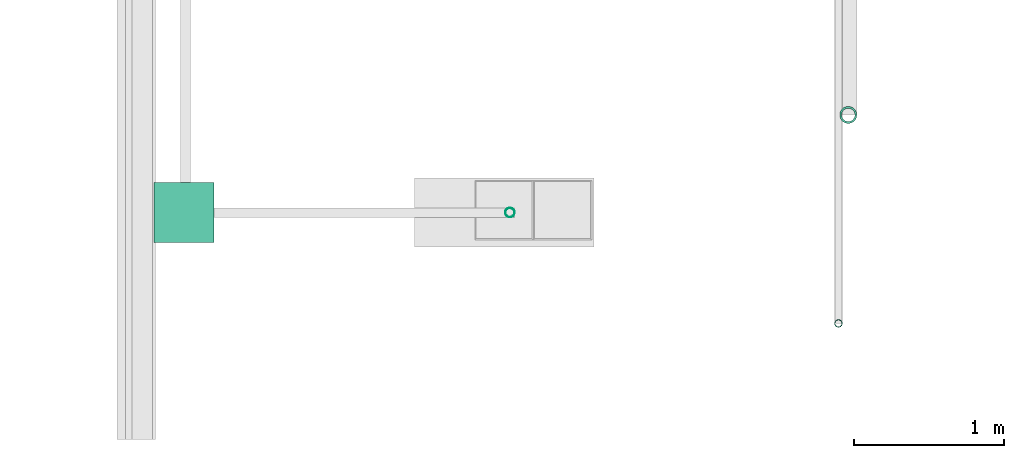
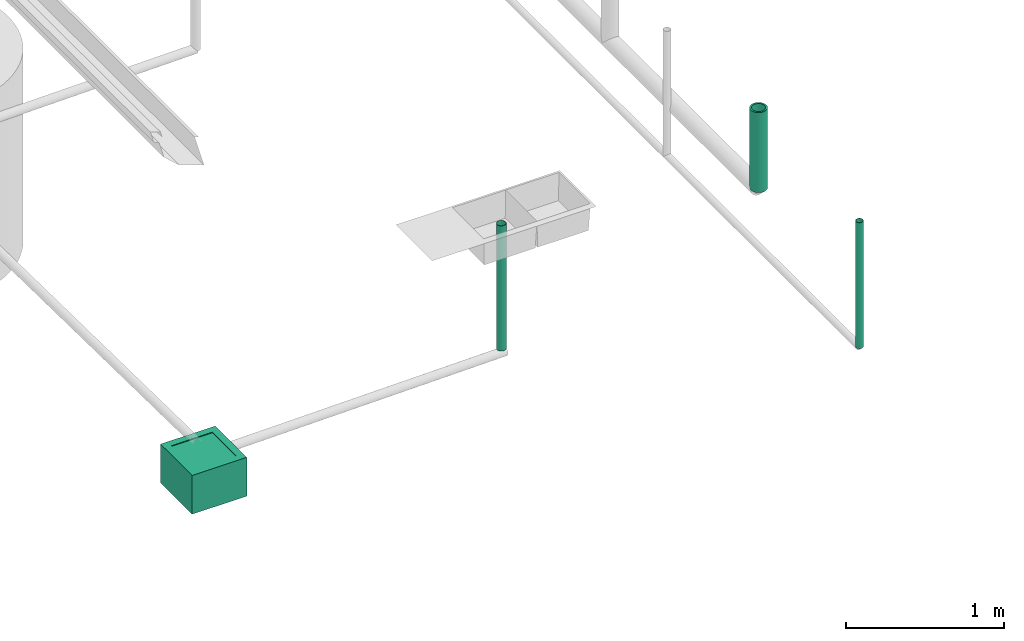
# One storey, part 10 of 15: 3 pipe segments, 2 distribution chamber elements.
"""IFC4X3_ADD2 building model written with IfcOpenShell, lengths in metres."""

from ifc_helpers import new_model, entity, si_unit, converted_unit, frame, origin_with_axes, origin_2d_with_axis, place, context, subcontext, project, spatial, hollow_circle, extrude, clip, halfspace, polygons, source, transform, mapped, material, material_profile, profile_set, profile_usage, type_object, type_shapes, element, save


model = new_model("IFC4X3_ADD2")

# Units and contexts
model_context = context("Model", 3, precision=1e-05, world=origin_with_axes())
plan_context = context("Plan", 2, precision=1e-05, world=origin_2d_with_axis())
body_context = subcontext(model_context, "Body", "Model", "MODEL_VIEW")
ifc_project = project(units=[si_unit("VOLUMEUNIT", "CUBIC_METRE"), si_unit("LENGTHUNIT", "METRE"), converted_unit("PLANEANGLEUNIT", "degree", entity("IfcReal", 0.0174532925199433), si_unit("PLANEANGLEUNIT", "RADIAN"), dimensions=[0, 0, 0, 0, 0, 0, 0]), si_unit("AREAUNIT", "SQUARE_METRE")], contexts=[model_context, plan_context])

# Site, building, storey
site_placement = place(None, origin_with_axes())
site = spatial("IfcSite", under=ifc_project, at=site_placement)
building_placement = place(site_placement, origin_with_axes())
building = spatial("IfcBuilding", under=site, at=building_placement, Name="Building")
storey_placement = place(building_placement, origin_with_axes())
storey = spatial("IfcBuildingStorey", under=building, at=storey_placement, Name="Plumbing")

# Distribution chamber elements
distribution_chamber_element_type = type_object("IfcDistributionChamberElementType", Name="1ft_WKR", PredefinedType="INSPECTIONCHAMBER")
shared_shape = source(origin_with_axes(), body_context, "Body", "Tessellation", [
    polygons([(0.0499999895691872, 0.0499999895691872, -0.0049999775364995), (0.0499999895691872, 0.349999994039536, 1.78813941431599e-08), (0.349999994039536, 0.0499999895691872, -0.0049999775364995), (0.0499999895691872, 0.0499999895691872, 1.78813941431599e-08), (0.349999994039536, 0.349999994039536, -0.0049999775364995), (0.349999994039536, 0.349999994039536, 1.78813941431599e-08), (0.0499999895691872, 0.349999994039536, -0.0049999775364995), (0.349999994039536, 0.0499999895691872, 1.78813941431599e-08)], [[[4, 8, 3, 1]], [[2, 4, 1, 7]], [[6, 2, 7, 5]], [[8, 6, 5, 3]], [[5, 7, 1, 3]], [[6, 8, 4, 2]]]),
    polygons([(0.400000005960464, 0.400000005960464, 8.94069707157996e-09), (0.400000005960464, 0.400000005960464, -0.299999982118607), (0.400000005960464, 0.0, 8.94069707157996e-09), (0.0, 0.400000005960464, 8.94069707157996e-09), (0.350000023841858, 0.350000023841858, 8.94069707157996e-09), (0.350000023841858, 0.0499999709427357, 8.94069707157996e-09), (0.0499999709427357, 0.350000023841858, 8.94069707157996e-09), (0.350000023841858, 0.350000023841858, -0.00499998638406396), (0.350000023841858, 0.0499999709427357, -0.00499998638406396), (0.0499999709427357, 0.350000023841858, -0.00499998638406396), (0.343575924634933, 0.343575924634933, -0.00499998638406396), (0.343575924634933, 0.0564240589737892, -0.00499998638406396), (0.0564240589737892, 0.343575924634933, -0.00499998638406396), (0.343575924634933, 0.343575924634933, -0.19999997317791), (0.343575924634933, 0.0564240589737892, -0.19999997317791), (0.0564240589737892, 0.343575924634933, -0.19999997317791), (0.0564240589737892, 0.0564240589737892, -0.19999997317791), (0.0564240589737892, 0.0564240589737892, -0.00499998638406396), (0.0499999709427357, 0.0499999709427357, -0.00499998638406396), (0.0499999709427357, 0.0499999709427357, 8.94069707157996e-09), (0.0, 0.0, 8.94069707157996e-09), (0.0, 0.0, -0.299999982118607), (0.0, 0.400000005960464, -0.299999982118607), (0.400000005960464, 0.0, -0.299999982118607)], [[[23, 4, 1, 2]], [[2, 1, 3, 24]], [[3, 1, 5, 6]], [[1, 4, 7, 5]], [[6, 5, 8, 9]], [[5, 7, 10, 8]], [[9, 8, 11, 12]], [[8, 10, 13, 11]], [[12, 11, 14, 15]], [[11, 13, 16, 14]], [[15, 14, 16, 17]], [[13, 18, 17, 16]], [[18, 12, 15, 17]], [[19, 9, 12, 18]], [[10, 19, 18, 13]], [[20, 6, 9, 19]], [[7, 20, 19, 10]], [[21, 3, 6, 20]], [[4, 21, 20, 7]], [[22, 21, 4, 23]], [[24, 3, 21, 22]], [[23, 2, 24, 22]]]),
])
type_shapes(distribution_chamber_element_type, [shared_shape])
for number, where, z_axis, x_axis, name in (
    (1, (4.56915855407715, 22.0496730804443, 0.299999982118607), (0.0, 0.0, 1.0), (1.0, 0.0, 0.0), "DistributionChamberElement"),
    (2, (4.56915855407715, 22.0496730804443, 0.299999982118607), (0.0, 0.0, 1.0), (1.0, 0.0, 0.0), "DistributionChamberElement"),
):
    element("IfcDistributionChamberElement", number, at=place(storey_placement, frame(where, z_axis=z_axis, x_axis=x_axis)), inside=storey, type_object=distribution_chamber_element_type, Name=name, context=body_context, shape_type="MappedRepresentation", body=[
        mapped(shared_shape, transform((0.0, 0.0, 0.0), x_axis=(1.0, 0.0, 0.0), y_axis=(0.0, 1.0, 0.0), z_axis=(0.0, 0.0, 1.0), scale=1.0)),
    ])

# Pipe segments
ifc_material_1 = material()
ifc_material_profile_1 = material_profile(ifc_material_1, hollow_circle(Radius=0.0571499988436699, WallThickness=0.012699999846518))
ifc_profile_set_1 = profile_set([ifc_material_profile_1])
ifc_profile_usage_1 = profile_usage(ifc_profile_set_1)
pipe_segment_type_1 = type_object("IfcPipeSegmentType", Name="4inch Tank", PredefinedType="FLEXIBLESEGMENT", material=ifc_profile_set_1)
pipe_segment_1_placement = place(storey_placement, frame((9.20528697967529, 22.9011688232422, 0.387610822916031), z_axis=(8.74228192060391e-08, -1.19209282445353e-07, 0.999999999999989), x_axis=(-0.999999999999921, -3.89414367418763e-07, 8.74227694680416e-08)))
element("IfcPipeSegment", 3, at=pipe_segment_1_placement, inside=storey, type_object=pipe_segment_type_1, material=ifc_profile_usage_1, Name="PipeSegment", PredefinedType="FLEXIBLESEGMENT", context=body_context, shape_type="SweptSolid", body=[
    extrude(hollow_circle(Radius=0.0571499988436699, WallThickness=0.012699999846518), origin_with_axes(), (0.0, 0.0, 1.0), 0.619042638491849),
])
ifc_material_2 = material(Name="Wall")
ifc_material_profile_2 = material_profile(ifc_material_2, hollow_circle(Radius=0.0253999996930361, WallThickness=0.0020000000949949))
ifc_profile_set_2 = profile_set([ifc_material_profile_2])
ifc_profile_usage_2 = profile_usage(ifc_profile_set_2)
ifc_material_profile_3 = material_profile(ifc_material_2, hollow_circle(Radius=0.0253999996930361, WallThickness=0.0020000000949949))
ifc_profile_set_3 = profile_set([ifc_material_profile_3])
pipe_segment_type_2 = type_object("IfcPipeSegmentType", Name="2inch-bath outlet", PredefinedType="FLEXIBLESEGMENT", material=ifc_profile_set_3)
pipe_segment_2_placement = place(storey_placement, frame((9.13959503173828, 21.5092372894287, 0.0252148024737835), z_axis=(-8.74227481517655e-08, -1.19209317972489e-07, 0.999999999999989), x_axis=(-0.999999999999921, -3.89414367418763e-07, -8.7422797889751e-08)))
element("IfcPipeSegment", 4, at=pipe_segment_2_placement, inside=storey, type_object=pipe_segment_type_2, material=ifc_profile_usage_2, Name="PipeSegment", context=body_context, shape_type="SweptSolid", body=[
    extrude(hollow_circle(Radius=0.0253999996930361, WallThickness=0.0020000000949949), origin_with_axes(), (0.0, 0.0, 1.0), 0.974785217445358),
])
ifc_material_profile_4 = material_profile(ifc_material_1, hollow_circle(Radius=0.031750001013279, WallThickness=0.0020000000949949))
ifc_profile_set_4 = profile_set([ifc_material_profile_4])
ifc_profile_usage_3 = profile_usage(ifc_profile_set_4)
ifc_material_profile_5 = material_profile(ifc_material_1, hollow_circle(Radius=0.031750001013279, WallThickness=0.0020000000949949))
ifc_profile_set_5 = profile_set([ifc_material_profile_5])
pipe_segment_type_3 = type_object("IfcPipeSegmentType", Name="2.5inch- Kitchen Outlet", PredefinedType="FLEXIBLESEGMENT", material=ifc_profile_set_5)
pipe_segment_3_placement = place(storey_placement, frame((6.9461817741394, 22.2486953735352, 0.267339468002319), z_axis=(0.0, 0.0, 1.0), x_axis=(-2.82129974493717e-07, -0.99999999999996, 0.0)))
element("IfcPipeSegment", 5, at=pipe_segment_3_placement, inside=storey, type_object=pipe_segment_type_3, material=ifc_profile_usage_3, Name="PipeSegment", context=body_context, shape_type="Clipping", body=[
    clip(extrude(hollow_circle(Radius=0.031750001013279, WallThickness=0.0020000000949949), origin_with_axes(), (0.0, 0.0, 1.0), 1.03179287348543), halfspace(frame((-7.90262220107252e-08, 0.0944556444883347, 0.0651487112045288), z_axis=(-2.58243545658843e-07, 0.0174522399902344, -0.999847650527954), x_axis=(0.999999999890522, 1.47971576012635e-05, 0.0)), False)),
])

save(model, "model.ifc")
